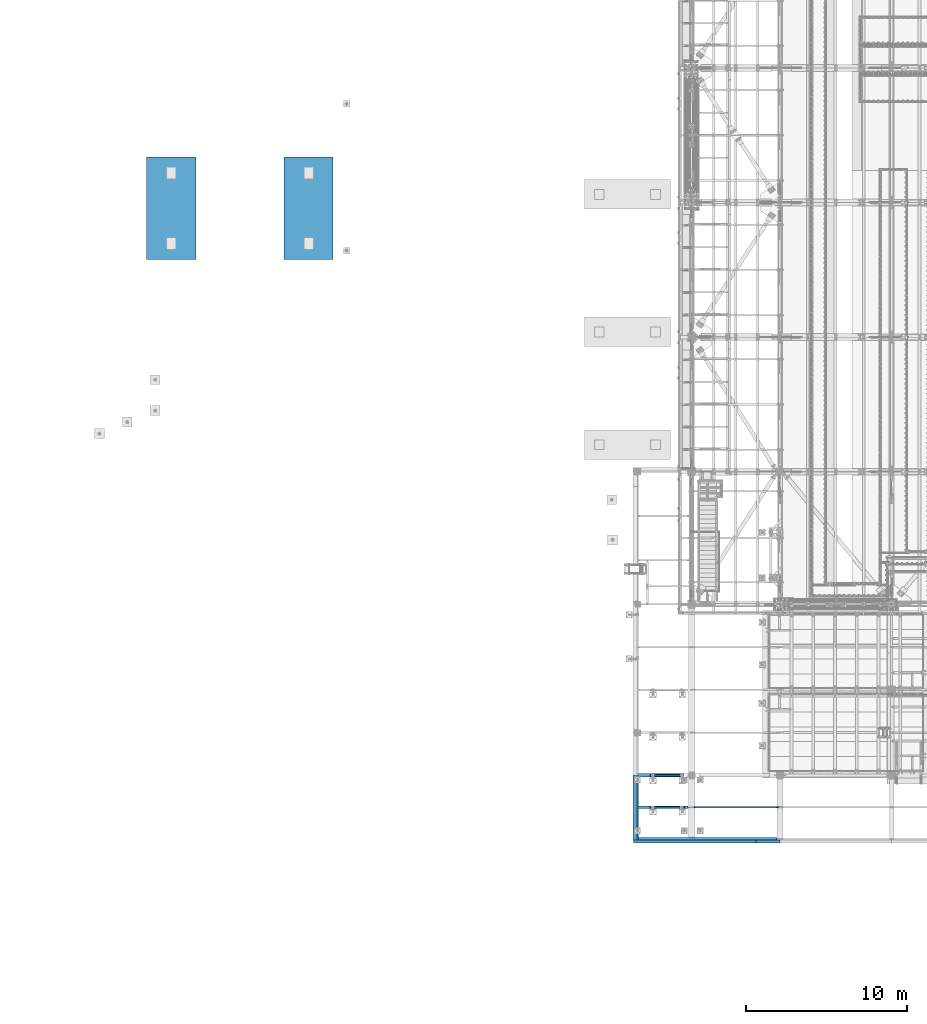
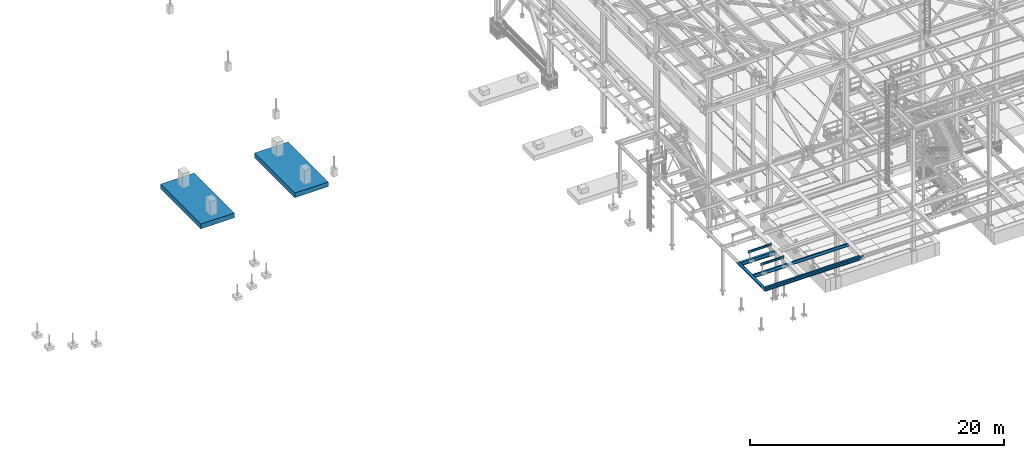
# One storey, part 1737 of 3843: 12 beams, 9 elements without a shape of their own.
"""IFC2X3 building model written with IfcOpenShell, lengths in millimetres."""

from ifc_helpers import new_model, si_unit, frame, origin_with_axes, place, context, subcontext, project, spatial, faceted_brep, material, type_object, element, aggregate, save


model = new_model("IFC2X3")

# Units and contexts
model_context = context("Model", 3, precision=1e-05, world=origin_with_axes())
body_context = subcontext(model_context, "Body", "Model", "MODEL_VIEW")
ifc_project = project(units=[si_unit("LENGTHUNIT", "METRE", prefix="MILLI"), si_unit("AREAUNIT", "SQUARE_METRE"), si_unit("VOLUMEUNIT", "CUBIC_METRE"), si_unit("MASSUNIT", "GRAM", prefix="KILO"), si_unit("TIMEUNIT", "SECOND"), si_unit("PLANEANGLEUNIT", "RADIAN"), si_unit("SOLIDANGLEUNIT", "STERADIAN"), si_unit("THERMODYNAMICTEMPERATUREUNIT", "DEGREE_CELSIUS"), si_unit("LUMINOUSINTENSITYUNIT", "LUMEN")], contexts=[model_context])

# Site, building, storey
site_placement = place(None, origin_with_axes())
site = spatial("IfcSite", under=ifc_project, at=site_placement, CompositionType="ELEMENT")
building_placement = place(site_placement, origin_with_axes())
building = spatial("IfcBuilding", under=site, at=building_placement, Name="Undefined", CompositionType="ELEMENT")
storey_placement = place(building_placement, origin_with_axes())
storey = spatial("IfcBuildingStorey", under=building, at=storey_placement, Name="Undefined", CompositionType="ELEMENT", Elevation=0.0)

# Assembly, beam
assembly_1_placement = place(storey_placement, origin_with_axes())
assembly_1 = element("IfcElementAssembly", 1, at=assembly_1_placement, inside=storey, Name="BEAM", AssemblyPlace="NOTDEFINED", PredefinedType="RIGID_FRAME")
ifc_material_1 = material(Name="STEEL/A992")
beam_type_1 = type_object("IfcBeamType", Name="W12X19", PredefinedType="NOTDEFINED")
beam_1_placement = place(assembly_1_placement, frame((36576.0, 13017.5, 34656.7125), z_axis=(0.0, 0.0, 1.0), x_axis=(1.0, 0.0, 0.0)))
beam_1 = element("IfcBeam", 2, at=beam_1_placement, type_object=beam_type_1, material=ifc_material_1, Name="BEAM", ObjectType="W12X19", context=body_context, shape_type="Brep", body=[
    faceted_brep([(22.2249999999985, -3.47514923012932, -144.462500000001), (22.2249999999985, -3.47492599268662, -153.987500000003), (136.525022932306, -3.4748875878322, -153.987500000003), (136.525022932379, -3.4751108252749, -144.462500000001), (136.525038833555, -50.7999999999993, -144.462500000001), (136.525038833555, -50.7999999999993, -153.987500000003), (5467.35000000001, 50.7999999999993, -144.462500000001), (5467.35000000001, 50.7999999999993, -153.987500000003), (136.52500168042, 50.7999999999993, -153.987500000003), (136.52500168042, 50.7999999999993, -144.462500000001), (136.525017581378, 3.47511084778307, -153.987500000003), (136.525017581444, 3.47488761034037, -144.462500000001), (22.2249999999985, 3.4750724433834, -153.987500000003), (22.2249999999985, 3.4748492059407, -144.462500000001), (22.2249999999985, 3.17499999999927, -144.462500000001), (5467.35000000001, 3.17499999999927, -144.462500000001), (204.88507970878, -3.17499999999927, 110.50422992259), (204.88507970878, 3.17499999999927, 110.50422992259), (200.025000190733, 3.17499999999927, 109.537499999999), (200.025000190733, -3.17499999999927, 109.537499999999), (209.005256176933, -3.17499999999927, 113.257243823064), (209.005256176933, 3.17499999999927, 113.257243823064), (211.758270077407, -3.17499999999927, 117.377420291217), (211.758270077407, 3.17499999999927, 117.377420291217), (212.724999999999, -3.17499999999927, 122.237499809264), (212.724999999999, 3.17499999999927, 122.237499809264), (212.724999999999, -50.7999999999993, 153.987500000003), (212.724999999999, 50.7999999999993, 153.987500000003), (212.724999999999, 50.7999999999993, 144.462500000001), (212.724999999999, 3.17499999999927, 144.462500000001), (212.724999999999, -3.17499999999927, 144.462500000001), (212.724999999999, -50.7999999999993, 144.462500000001), (5283.2, 50.7999999999993, 144.462500000001), (5283.2, 3.17499999999927, 144.462500000001), (5467.35000000001, 3.17499999999927, 103.187500000007), (5467.35000000001, 3.17499999999927, -127.412499999999), (22.2249999999985, 3.17499999999927, -140.112500000003), (22.2249999999985, 3.17499999999927, 90.4875000000029), (22.2249999999985, 3.17499999999927, 109.537499999999), (5283.2, 3.17499999999927, 122.237499809264), (5284.1667299226, 3.17499999999927, 117.377420291217), (5286.91974382307, 3.17499999999927, 113.257243823064), (5291.03992029122, 3.17499999999927, 110.50422992259), (5295.89999980927, 3.17499999999927, 109.537499999999), (5467.35000000001, 3.17499999999927, 109.537499999999), (22.2249999999985, -3.17499999999927, 109.537499999999), (5291.03992029122, -3.17499999999927, 110.50422992259), (5286.91974382307, -3.17499999999927, 113.257243823064), (5284.1667299226, -3.17499999999927, 117.377420291217), (5283.2, -3.17499999999927, 122.237499809264), (5283.2, -3.17499999999927, 144.462500000001), (22.2249999999985, -3.17499999999927, -144.462500000001), (5467.35000000001, -3.17499999999927, -144.462500000001), (5467.35000000001, -3.17499999999927, 109.537499999999), (5295.89999980927, -3.17499999999927, 109.537499999999), (5283.2, -50.7999999999993, 144.462500000001), (5283.2, -50.7999999999993, 153.987500000003), (5283.2, 50.7999999999993, 153.987500000003), (5467.35000000001, -50.7999999999993, -144.462500000001), (5467.35000000001, -50.7999999999993, -153.987500000003)], [[[0, 1, 2, 3]], [[4, 3, 2, 5]], [[6, 7, 8, 9]], [[9, 8, 10, 11]], [[11, 10, 12, 13]], [[14, 15, 6, 9, 11, 13]], [[16, 17, 18, 19]], [[20, 21, 17, 16]], [[22, 23, 21, 20]], [[24, 25, 23, 22]], [[26, 27, 28, 29, 25, 24, 30, 31]], [[29, 28, 32, 33]], [[34, 35, 15, 14, 36, 37, 38, 18, 17, 21, 23, 25, 29, 33, 39, 40, 41, 42, 43, 44]], [[19, 18, 38, 45]], [[46, 47, 48, 49, 50, 30, 24, 22, 20, 16, 19, 45, 51, 52, 53, 54]], [[31, 30, 50, 55]], [[26, 31, 55, 56]], [[27, 26, 56, 57]], [[28, 27, 57, 32]], [[56, 55, 50, 49, 39, 33, 32, 57]], [[48, 40, 39, 49]], [[47, 41, 40, 48]], [[46, 42, 41, 47]], [[54, 43, 42, 46]], [[53, 44, 43, 54]], [[52, 58, 59, 7, 6, 15, 35, 34, 44, 53]], [[59, 58, 4, 5]], [[1, 12, 10, 8, 7, 59, 5, 2]], [[51, 45, 38, 37, 36, 14, 13, 12, 1, 0]], [[58, 52, 51, 0, 3, 4]]]),
])
aggregate(assembly_1, [beam_1])

assembly_2_placement = place(storey_placement, origin_with_axes())
assembly_2 = element("IfcElementAssembly", 3, at=assembly_2_placement, inside=storey, Name="BEAM", AssemblyPlace="NOTDEFINED", PredefinedType="RIGID_FRAME")
beam_2_placement = place(assembly_2_placement, frame((33223.2, 11036.3, 34656.7125), z_axis=(0.0, 0.0, 1.0), x_axis=(0.0, 1.0, 0.0)))
beam_2 = element("IfcBeam", 4, at=beam_2_placement, type_object=beam_type_1, material=ifc_material_1, Name="BEAM", ObjectType="W12X19", context=body_context, shape_type="Brep", body=[
    faceted_brep([(106.362500190742, -3.17500000000291, 122.237500000003), (106.362500190742, 3.17500000000291, 122.237500000003), (17.4624999999942, 3.17500000000291, 122.237500000003), (17.4624999999942, -3.17500000000291, 122.237500000003), (111.222579708789, -3.17500000000291, 123.204229922594), (111.222579708789, 3.17500000000291, 123.204229922594), (115.342756176942, -3.17500000000291, 125.957243823068), (115.342756176942, 3.17500000000291, 125.957243823068), (118.09577007742, -3.17500000000291, 130.077420291222), (118.09577007742, 3.17500000000291, 130.077420291222), (119.062500000007, -3.17500000000291, 134.937499809268), (119.062500000007, 3.17500000000291, 134.937499809268), (119.062500000007, -50.8000000000029, 153.987500000003), (119.062500000007, 50.8000000000029, 153.987500000003), (119.062500000007, 50.8000000000029, 144.462500000001), (119.062500000007, 3.17500000000291, 144.462500000001), (119.062500000007, -3.17500000000291, 144.462500000001), (119.062500000007, -50.8000000000029, 144.462500000001), (17.4624999999942, -3.17500000000291, -144.462500000001), (17.4624999999942, -50.8000000000029, -144.462500000001), (3944.93749999999, -50.8000000000029, -144.462500000001), (3944.93749999999, -3.17500000000291, -144.462500000001), (17.4624999999942, -50.8000000000029, -153.987500000003), (3944.93749999999, -50.8000000000029, -153.987500000003), (17.4624999999942, 50.8000000000029, -153.987500000003), (3944.93749999999, 50.8000000000029, -153.987500000003), (17.4624999999942, 50.8000000000029, -144.462500000001), (3944.93749999999, 50.8000000000029, -144.462500000001), (17.4624999999942, 3.17500000000291, -144.462500000001), (3944.93749999999, 3.17500000000291, -144.462500000001), (3944.93749999999, -3.17500000000291, 115.887499999997), (3944.93749999999, -3.17500000000291, -114.712500000001), (3944.93749999999, 3.17500000000291, 122.237500000003), (3944.93749999999, -3.17500000000291, 122.237500000003), (3856.03749980926, 3.17500000000291, 122.237500000003), (3856.03749980926, -3.17500000000291, 122.237500000003), (3851.17742029121, 3.17500000000291, 123.204229922594), (3851.17742029121, -3.17500000000291, 123.204229922594), (3847.05724382306, 3.17500000000291, 125.957243823068), (3847.05724382306, -3.17500000000291, 125.957243823068), (3844.30422992258, 3.17500000000291, 130.077420291222), (3844.30422992258, -3.17500000000291, 130.077420291222), (3843.33749999999, 3.17500000000291, 134.937499809268), (3843.33749999999, -3.17500000000291, 134.937499809268), (3843.33749999999, -50.8000000000029, 153.987500000003), (3843.33749999999, -50.8000000000029, 144.462500000001), (3843.33749999999, -3.17500000000291, 144.462500000001), (3843.33749999999, 3.17500000000291, 144.462500000001), (3843.33749999999, 50.8000000000029, 144.462500000001), (3843.33749999999, 50.8000000000029, 153.987500000003), (17.4625000000015, -3.17500000000291, 115.887499999997), (17.4625000000015, -3.17500000000291, -114.712500000001)], [[[0, 1, 2, 3]], [[4, 5, 1, 0]], [[6, 7, 5, 4]], [[8, 9, 7, 6]], [[10, 11, 9, 8]], [[12, 13, 14, 15, 11, 10, 16, 17]], [[18, 19, 20, 21]], [[19, 22, 23, 20]], [[22, 24, 25, 23]], [[24, 26, 27, 25]], [[26, 28, 29, 27]], [[30, 31, 21, 20, 23, 25, 27, 29, 32, 33]], [[33, 32, 34, 35]], [[35, 34, 36, 37]], [[37, 36, 38, 39]], [[39, 38, 40, 41]], [[41, 40, 42, 43]], [[44, 45, 46, 43, 42, 47, 48, 49]], [[45, 44, 12, 17]], [[46, 45, 17, 16]], [[8, 6, 4, 0, 3, 50, 51, 18, 21, 31, 30, 33, 35, 37, 39, 41, 43, 46, 16, 10]], [[28, 26, 24, 22, 19, 18, 51, 50, 3, 2]], [[47, 42, 40, 38, 36, 34, 32, 29, 28, 2, 1, 5, 7, 9, 11, 15]], [[48, 47, 15, 14]], [[49, 48, 14, 13]], [[44, 49, 13, 12]]]),
])

assembly_3_placement = place(storey_placement, origin_with_axes())
assembly_3 = element("IfcElementAssembly", 5, at=assembly_3_placement, inside=storey, Name="BEAM", AssemblyPlace="NOTDEFINED", PredefinedType="RIGID_FRAME")
beam_type_2 = type_object("IfcBeamType", Name="W8X13", PredefinedType="NOTDEFINED")
beam_3_placement = place(assembly_3_placement, frame((36118.8, 13017.5, 35521.8999969482), z_axis=(0.0, 0.0, 1.0), x_axis=(-1.0, 0.0, 0.0)))
beam_3 = element("IfcBeam", 6, at=beam_3_placement, type_object=beam_type_2, material=ifc_material_1, Name="BEAM", ObjectType="W8X13", context=body_context, shape_type="Brep", body=[
    faceted_brep([(0.0, 50.7999999999993, -101.599999999999), (0.0, 50.7999999999993, -95.25), (2133.6, 50.7999999999993, -95.25), (2133.6, 50.7999999999993, -101.599999999999), (0.0, 3.17499999999927, -95.25), (2133.6, 3.17499999999927, -95.25), (-2.44140610448085e-05, 3.17500000000291, 95.2499999999927), (2133.6, 3.17499999999927, 95.25), (0.0, 50.7999999999993, 95.25), (2133.6, 50.7999999999993, 95.25), (0.0, 50.7999999999993, 101.599999999999), (2133.6, 50.7999999999993, 101.599999999999), (0.0, -50.7999999999993, 101.599999999999), (2133.6, -50.7999999999993, 101.599999999999), (0.0, -50.7999999999993, 95.25), (2133.6, -50.7999999999993, 95.25), (0.0, -3.17499999999927, 95.25), (2133.6, -3.17499999999927, 95.25), (0.0, -3.17499999999927, -95.25), (2133.6, -3.17499999999927, -95.25), (0.0, -50.7999999999993, -95.25), (2133.6, -50.7999999999993, -95.25), (0.0, -50.7999999999993, -101.599999999999), (2133.6, -50.7999999999993, -101.599999999999)], [[[0, 1, 2, 3]], [[1, 4, 5, 2]], [[4, 6, 7, 5]], [[6, 8, 9, 7]], [[8, 10, 11, 9]], [[10, 12, 13, 11]], [[12, 14, 15, 13]], [[14, 16, 17, 15]], [[16, 18, 19, 17]], [[18, 20, 21, 19]], [[20, 22, 23, 21]], [[22, 0, 3, 23]], [[5, 7, 9, 11, 13, 15, 17, 19, 21, 23, 3, 2]], [[22, 20, 18, 16, 14, 12, 10, 8, 6, 4, 1, 0]]]),
])
aggregate(assembly_3, [beam_3])

assembly_4_placement = place(storey_placement, origin_with_axes())
assembly_4 = element("IfcElementAssembly", 7, at=assembly_4_placement, inside=storey, Name="BEAM", AssemblyPlace="NOTDEFINED", PredefinedType="RIGID_FRAME")
beam_4_placement = place(assembly_4_placement, frame((36118.8, 14998.7, 35521.8999969482), z_axis=(0.0, 0.0, 1.0), x_axis=(-1.0, 0.0, 0.0)))
beam_4 = element("IfcBeam", 8, at=beam_4_placement, type_object=beam_type_2, material=ifc_material_1, Name="BEAM", ObjectType="W8X13", context=body_context, shape_type="Brep", body=[
    faceted_brep([(0.0, 50.7999999999993, -101.599999999999), (0.0, 50.7999999999993, -95.25), (2133.6, 50.7999999999993, -95.25), (2133.6, 50.7999999999993, -101.599999999999), (0.0, 3.17499999999927, -95.25), (2133.6, 3.17499999999927, -95.25), (-2.44140610448085e-05, 3.17500000000291, 95.2499999999927), (2133.6, 3.17499999999927, 95.25), (0.0, 50.7999999999993, 95.25), (2133.6, 50.7999999999993, 95.25), (0.0, 50.7999999999993, 101.599999999999), (2133.6, 50.7999999999993, 101.599999999999), (0.0, -50.7999999999993, 101.599999999999), (2133.6, -50.7999999999993, 101.599999999999), (0.0, -50.7999999999993, 95.25), (2133.6, -50.7999999999993, 95.25), (0.0, -3.17499999999927, 95.25), (2133.6, -3.17499999999927, 95.25), (0.0, -3.17499999999927, -95.25), (2133.6, -3.17499999999927, -95.25), (0.0, -50.7999999999993, -95.25), (2133.6, -50.7999999999993, -95.25), (0.0, -50.7999999999993, -101.599999999999), (2133.6, -50.7999999999993, -101.599999999999)], [[[0, 1, 2, 3]], [[1, 4, 5, 2]], [[4, 6, 7, 5]], [[6, 8, 9, 7]], [[8, 10, 11, 9]], [[10, 12, 13, 11]], [[12, 14, 15, 13]], [[14, 16, 17, 15]], [[16, 18, 19, 17]], [[18, 20, 21, 19]], [[20, 22, 23, 21]], [[22, 0, 3, 23]], [[5, 7, 9, 11, 13, 15, 17, 19, 21, 23, 3, 2]], [[22, 20, 18, 16, 14, 12, 10, 8, 6, 4, 1, 0]]]),
])
aggregate(assembly_4, [beam_4])

# Beam
ifc_material_2 = material(Name="STEEL/A36")
beam_type_3 = type_object("IfcBeamType", PredefinedType="NOTDEFINED")
beam_5_placement = place(assembly_2_placement, frame((33223.2, 12993.8855, 34813.875), z_axis=(0.0, -1.0, 0.0), x_axis=(-1.0, 0.0, 0.0)))
beam_5 = element("IfcBeam", 9, at=beam_5_placement, type_object=beam_type_3, material=ifc_material_2, Name="BENT_PLATE", context=body_context, shape_type="Brep", body=[
    faceted_brep([(0.0, -3.17500000000291, -2002.036), (0.0, -3.17500000000291, 2002.036), (0.0, 3.17500000000291, 2002.036), (0.0, 3.17500000000291, -2002.036), (279.399993896484, 3.17500000000291, 2002.036), (279.399993896484, 3.17500000000291, -2002.036), (273.049993896479, -3.17500000000291, -2002.036), (273.049993896479, -3.17500000000291, 2002.036), (279.399993896484, -136.524996948239, 2002.036), (279.399993896484, -136.524996948239, -2002.036), (273.049993896479, -136.524996948239, 2002.036), (273.049993896479, -136.524996948239, -2002.036)], [[[0, 1, 2, 3]], [[3, 2, 4, 5]], [[1, 0, 6, 7]], [[5, 4, 8, 9]], [[4, 2, 1, 7, 10, 8]], [[7, 6, 11, 10]], [[6, 0, 3, 5, 9, 11]], [[10, 11, 9, 8]]]),
])

aggregate(assembly_2, [beam_5, beam_2])

# Assembly, beams
assembly_5_placement = place(storey_placement, origin_with_axes())
assembly_5 = element("IfcElementAssembly", 10, at=assembly_5_placement, inside=storey, Name="BEAM", AssemblyPlace="NOTDEFINED", PredefinedType="RIGID_FRAME")
beam_type_4 = type_object("IfcBeamType", PredefinedType="NOTDEFINED")
beam_6_placement = place(assembly_5_placement, frame((36753.8, 10985.5, 34813.875), z_axis=(-1.0, 0.0, 0.0), x_axis=(0.0, -1.0, 0.0)))
beam_6 = element("IfcBeam", 11, at=beam_6_placement, type_object=beam_type_4, material=ifc_material_2, Name="BENT_PLATE", context=body_context, shape_type="Brep", body=[
    faceted_brep([(0.0, -3.17500000000291, -3810.0), (0.0, -3.17500000000291, 3810.0), (0.0, 3.17500000000291, 3810.0), (0.0, 3.17500000000291, -3810.0), (171.450003051756, 3.17500000000291, 3810.0), (171.450003051756, 3.17500000000291, -3810.0), (177.800003051754, -3.17500000000291, -3810.0), (177.800003051754, -3.17500000000291, 3810.0), (171.450003051756, 136.524996948239, 3810.0), (171.450003051756, 136.524996948239, -3810.0), (177.800003051754, 136.524996948239, 3810.0), (177.800003051754, 136.524996948239, -3810.0)], [[[0, 1, 2, 3]], [[3, 2, 4, 5]], [[1, 0, 6, 7]], [[5, 4, 8, 9]], [[4, 2, 1, 7, 10, 8]], [[7, 6, 11, 10]], [[6, 0, 3, 5, 9, 11]], [[10, 11, 9, 8]]]),
])
beam_7_placement = place(assembly_5_placement, frame((41311.5125, 10985.5, 34813.875), z_axis=(-1.0, 0.0, 0.0), x_axis=(0.0, -1.0, 0.0)))
beam_7 = element("IfcBeam", 12, at=beam_7_placement, type_object=beam_type_4, material=ifc_material_2, Name="BENT_PLATE", context=body_context, shape_type="Brep", body=[
    faceted_brep([(174.625003051762, 7.27595761418343e-12, 747.712500000009), (171.450003051756, 3.17500000000291, 744.537500000006), (0.0, 3.17500000000291, 744.537500000006), (0.0, 7.27595761418343e-12, 747.712500000001), (174.625003051762, 136.524996948239, 747.712500000001), (171.450003051756, 136.524996948239, 744.537500000006), (177.800003051754, -3.17500000000291, -747.712500000001), (0.0, -3.17500000000291, -747.712500000001), (0.0, 3.17500000000291, -747.712500000001), (171.450003051756, 3.17500000000291, -747.712500000001), (171.450003051756, 136.524996948239, -747.712500000001), (177.800003051754, 136.524996948239, -747.712500000001), (177.800003051754, -3.17500000000291, 747.712500000001), (177.800003051754, 136.524996948239, 747.712500000001), (0.0, -3.17500000000291, 747.712500000001)], [[[0, 1, 2, 3]], [[4, 5, 1, 0]], [[6, 7, 8, 9, 10, 11]], [[12, 6, 11, 13]], [[14, 7, 6, 12]], [[8, 7, 14, 3, 2]], [[9, 8, 2, 1]], [[10, 9, 1, 5]], [[13, 11, 10, 5, 4]], [[14, 12, 13, 4, 0, 3]]]),
])

# Assembly, beam
assembly_6_placement = place(storey_placement, origin_with_axes())
assembly_6 = element("IfcElementAssembly", 13, at=assembly_6_placement, inside=storey, Name="BEAM", AssemblyPlace="NOTDEFINED", PredefinedType="RIGID_FRAME")
beam_type_5 = type_object("IfcBeamType", Name="W14X22", PredefinedType="NOTDEFINED")
beam_8_placement = place(assembly_6_placement, frame((33223.2, 13017.5, 34636.075), z_axis=(0.0, 0.0, 1.0), x_axis=(1.0, 0.0, 0.0)))
beam_8 = element("IfcBeam", 14, at=beam_8_placement, type_object=beam_type_5, material=ifc_material_1, Name="BEAM", ObjectType="W14X22", context=body_context, shape_type="Brep", body=[
    faceted_brep([(15.875, -3.17499999999927, -111.124999999985), (15.875, 3.17499999999927, -111.124999999985), (50.8000001907494, 3.17499999999927, -111.124999999985), (50.8000001907494, -3.17499999999927, -111.124999999985), (55.6600797087958, 3.17499999999927, -112.091729922577), (55.6600797087958, -3.17499999999927, -112.091729922577), (59.7802561769495, 3.17499999999927, -114.844743823051), (59.7802561769495, -3.17499999999927, -114.844743823051), (62.5332700774234, 3.17499999999927, -118.964920291204), (62.5332700774234, -3.17499999999927, -118.964920291204), (63.5000000000146, -3.17499999999927, -123.824999809251), (63.5000000000146, 3.17499999999927, -123.824999809251), (63.5000000000146, 3.17499999999927, -166.6875), (63.5000000000146, 63.5, -166.6875), (63.5000000000146, 63.5, -174.625), (63.5000000000146, -63.5, -174.625), (63.5000000000146, -63.5, -166.6875), (63.5000000000146, -3.17499999999927, -166.6875), (63.5000000000146, 3.17499999999927, 166.6875), (63.5000000000146, 63.5, 166.6875), (3141.66250000001, 63.5, 166.6875), (3141.66250000001, 3.17499999999927, 166.6875), (50.8000001907494, -3.17499999999927, 149.225000000013), (50.8000001907494, 3.17499999999927, 149.225000000013), (15.875, 3.17499999999927, 149.225000000013), (15.875, -3.17499999999927, 149.225000000013), (55.6600797087958, -3.17499999999927, 150.191729922604), (55.6600797087958, 3.17499999999927, 150.191729922604), (59.7802561769495, -3.17499999999927, 152.944743823078), (59.7802561769495, 3.17499999999927, 152.944743823078), (62.5332700774234, -3.17499999999927, 157.064920291232), (62.5332700774234, 3.17499999999927, 157.064920291232), (63.5000000000146, -3.17499999999927, 161.924999809278), (63.5000000000146, 3.17499999999927, 161.924999809278), (63.5000000000146, -63.5, 174.625), (63.5000000000146, 63.5, 174.625), (63.5000000000146, -3.17499999999927, 166.6875), (63.5000000000146, -63.5, 166.6875), (3141.66250000001, -3.17499999999927, 166.6875), (3141.66250000001, -63.5, 166.6875), (3141.66250000001, -63.5, 174.625), (3141.66250000001, 63.5, 174.625), (3141.66250000001, -3.17499999999927, 142.874999809268), (3141.66250000001, 3.17499999999927, 142.874999809268), (3142.6292299226, -3.17499999999927, 138.014920291222), (3142.6292299226, 3.17499999999927, 138.014920291222), (3145.38224382308, -3.17499999999927, 133.894743823068), (3145.38224382308, 3.17499999999927, 133.894743823068), (3149.50242029123, -3.17499999999927, 131.141729922594), (3149.50242029123, 3.17499999999927, 131.141729922594), (3154.36249980928, -3.17499999999927, 130.175000000003), (3154.36249980928, 3.17499999999927, 130.175000000003), (3330.575, -3.17499999999927, 130.175000000003), (3330.575, 3.17499999999927, 130.175000000003), (3330.575, 3.17499999999927, -119.475000000006), (3330.575, 3.17499999999927, 111.125), (3330.575, -3.17499999999927, -130.174999999996), (3330.575, 3.17499999999927, -130.174999999996), (3154.36249980928, -3.17499999999927, -130.174999999996), (3154.36249980928, 3.17499999999927, -130.174999999996), (3149.50242029123, -3.17499999999927, -131.141729922587), (3149.50242029123, 3.17499999999927, -131.141729922587), (3145.38224382308, -3.17499999999927, -133.894743823061), (3145.38224382308, 3.17499999999927, -133.894743823061), (3142.6292299226, -3.17499999999927, -138.014920291214), (3142.6292299226, 3.17499999999927, -138.014920291214), (3141.66250000001, -3.17499999999927, -142.874999809261), (3141.66250000001, 3.17499999999927, -142.874999809261), (3141.66250000001, -3.17499999999927, -166.6875), (3141.66250000001, -63.5, -166.6875), (3141.66250000001, -63.5, -174.625), (3141.66250000001, 63.5, -174.625), (3141.66250000001, 63.5, -166.6875), (3141.66250000001, 3.17499999999927, -166.6875), (15.875, 3.17499999999927, -94.0750000000044), (15.875, 3.17499999999927, 136.524999999994)], [[[0, 1, 2, 3]], [[3, 2, 4, 5]], [[5, 4, 6, 7]], [[7, 6, 8, 9]], [[10, 11, 12, 13, 14, 15, 16, 17]], [[9, 8, 11, 10]], [[18, 19, 20, 21]], [[22, 23, 24, 25]], [[26, 27, 23, 22]], [[28, 29, 27, 26]], [[30, 31, 29, 28]], [[32, 33, 31, 30]], [[34, 35, 19, 18, 33, 32, 36, 37]], [[37, 36, 38, 39]], [[34, 37, 39, 40]], [[35, 34, 40, 41]], [[19, 35, 41, 20]], [[40, 39, 38, 42, 43, 21, 20, 41]], [[44, 45, 43, 42]], [[46, 47, 45, 44]], [[48, 49, 47, 46]], [[50, 51, 49, 48]], [[52, 53, 51, 50]], [[54, 55, 53, 52, 56, 57]], [[56, 58, 59, 57]], [[60, 61, 59, 58]], [[62, 63, 61, 60]], [[64, 65, 63, 62]], [[66, 67, 65, 64]], [[68, 69, 70, 71, 72, 73, 67, 66]], [[69, 68, 17, 16]], [[70, 69, 16, 15]], [[71, 70, 15, 14]], [[72, 71, 14, 13]], [[73, 72, 13, 12]], [[6, 4, 2, 1, 74, 75, 24, 23, 27, 29, 31, 33, 18, 21, 43, 45, 47, 49, 51, 53, 55, 54, 57, 59, 61, 63, 65, 67, 73, 12, 11, 8]], [[25, 24, 75, 74, 1, 0]], [[68, 66, 64, 62, 60, 58, 56, 52, 50, 48, 46, 44, 42, 38, 36, 32, 30, 28, 26, 22, 25, 0, 3, 5, 7, 9, 10, 17]]]),
])
aggregate(assembly_6, [beam_8])

# Beam
beam_type_6 = type_object("IfcBeamType", Name="W14X53", PredefinedType="NOTDEFINED")
beam_9_placement = place(assembly_5_placement, frame((33172.4, 11036.3, 34634.4875), z_axis=(0.0, 0.0, 1.0), x_axis=(1.0, 0.0, 0.0)))
beam_9 = element("IfcBeam", 15, at=beam_9_placement, type_object=beam_type_6, material=ifc_material_1, Name="BEAM", ObjectType="W14X53", context=body_context, shape_type="Brep", body=[
    faceted_brep([(8693.15000000001, -4.76250000000073, -158.75), (8693.15000000001, -101.6, -158.75), (8693.15000000001, -101.6, -176.212500000001), (8693.15000000001, 101.6, -176.212500000001), (8693.15000000001, 101.6, -158.75), (8693.15000000001, 4.76250000000073, -158.75), (8693.15000000001, 4.76250000000073, -157.162499809267), (8693.15000000001, -4.76250000000073, -157.162499809267), (8694.11672992259, 4.76250000000073, -152.30242029122), (8694.11672992259, -4.76250000000073, -152.30242029122), (8696.86974382307, 4.76250000000073, -148.182243823067), (8696.86974382307, -4.76250000000073, -148.182243823067), (8700.98992029123, 4.76250000000073, -145.429229922593), (8700.98992029123, -4.76250000000073, -145.429229922593), (8705.84999980927, 4.76250000000073, -144.462500000001), (8705.84999980927, -4.76250000000073, -144.462500000001), (8870.95000000001, -4.76250000000073, -144.462500000001), (8870.95000000001, 4.76250000000073, -144.462500000001), (0.0, 4.76249999999709, 158.749999526888), (0.0, 101.6, 158.75), (8693.15000000001, 101.6, 158.75), (8693.15000000001, 4.76250000000073, 158.75), (0.0, -101.6, -176.212500000001), (0.0, -101.6, -158.75), (0.0, -4.76250000000073, -158.75), (0.0, -4.76249999999709, 158.749999526888), (0.0, -101.6, 158.75), (0.0, -101.6, 176.212500000001), (0.0, 101.6, 176.212500000001), (0.0, 4.76250000000073, -158.75), (0.0, 101.6, -158.75), (0.0, 101.6, -176.212500000001), (8693.15000000001, -4.76250000000073, 158.75), (8693.15000000001, -101.6, 158.75), (8693.15000000001, -101.6, 176.212500000001), (8693.15000000001, 101.6, 176.212500000001), (8693.15000000001, -4.76250000000073, 157.162499809267), (8693.15000000001, 4.76250000000073, 157.162499809267), (8694.11672992259, -4.76250000000073, 152.30242029122), (8694.11672992259, 4.76250000000073, 152.30242029122), (8696.86974382307, -4.76250000000073, 148.182243823067), (8696.86974382307, 4.76250000000073, 148.182243823067), (8700.98992029123, -4.76250000000073, 145.429229922593), (8700.98992029123, 4.76250000000073, 145.429229922593), (8705.84999980927, -4.76250000000073, 144.462500000001), (8705.84999980927, 4.76250000000073, 144.462500000001), (8870.95000000001, -4.76250000000073, 144.462500000001), (8870.95000000001, 4.76250000000073, 144.462500000001), (8870.95000000001, 4.76250000000073, -92.4875000000029), (8870.95000000001, 4.76250000000073, 138.112500000003)], [[[0, 1, 2, 3, 4, 5, 6, 7]], [[7, 6, 8, 9]], [[9, 8, 10, 11]], [[11, 10, 12, 13]], [[13, 12, 14, 15]], [[16, 15, 14, 17]], [[18, 19, 20, 21]], [[22, 23, 24, 25, 26, 27, 28, 19, 18, 29, 30, 31]], [[26, 25, 32, 33]], [[27, 26, 33, 34]], [[28, 27, 34, 35]], [[19, 28, 35, 20]], [[34, 33, 32, 36, 37, 21, 20, 35]], [[38, 39, 37, 36]], [[40, 41, 39, 38]], [[42, 43, 41, 40]], [[44, 45, 43, 42]], [[46, 47, 45, 44]], [[48, 49, 47, 46, 16, 17]], [[12, 10, 8, 6, 5, 29, 18, 21, 37, 39, 41, 43, 45, 47, 49, 48, 17, 14]], [[30, 29, 5, 4]], [[31, 30, 4, 3]], [[22, 31, 3, 2]], [[23, 22, 2, 1]], [[24, 23, 1, 0]], [[46, 44, 42, 40, 38, 36, 32, 25, 24, 0, 7, 9, 11, 13, 15, 16]]]),
])

aggregate(assembly_5, [beam_6, beam_7, beam_9])

# Assembly, beam
assembly_7_placement = place(storey_placement, origin_with_axes())
assembly_7 = element("IfcElementAssembly", 16, at=assembly_7_placement, inside=storey, Name="BEAM", AssemblyPlace="NOTDEFINED", PredefinedType="RIGID_FRAME")
beam_10_placement = place(assembly_7_placement, frame((33172.4, 14998.7, 34634.4875), z_axis=(0.0, 0.0, 1.0), x_axis=(1.0, 0.0, 0.0)))
beam_10 = element("IfcBeam", 17, at=beam_10_placement, type_object=beam_type_6, material=ifc_material_1, Name="BEAM", ObjectType="W14X53", context=body_context, shape_type="Brep", body=[
    faceted_brep([(3184.63795585983, -4.76250000000073, -158.352999496463), (3184.63795585983, -4.76250000000073, -158.75), (3184.63795585983, -101.6, -158.75), (3184.63795585983, -101.6, -176.212500000001), (3184.63795585983, 101.6, -176.212500000001), (3184.63795585983, 101.6, -158.75), (3184.63795585983, 4.76250000000073, -158.75), (3184.63795585983, 4.76250000000073, -158.352999496463), (0.0, 101.6, 158.75), (0.0, 101.6, 176.212500000001), (3185.55539706808, 101.6, 176.212500000001), (3195.63701066062, 101.6, 158.75), (0.0, 4.76249999999709, 158.749999526888), (3195.63701066062, 4.76250000000073, 158.75), (0.0, -101.6, -176.212500000001), (0.0, -101.6, -158.75), (0.0, -4.76250000000073, -158.75), (0.0, -4.76249999999709, 158.749999526888), (0.0, -101.6, 158.75), (0.0, -101.6, 176.212500000001), (0.0, 4.76250000000073, -158.75), (0.0, 101.6, -158.75), (0.0, 101.6, -176.212500000001), (3195.63701066062, -4.76250000000073, 158.75), (3195.63701066062, -101.6, 158.75), (3185.55539706808, -101.6, 176.212500000001), (3195.86621069914, -4.76250000000073, 158.352999496463), (3195.86621069914, 4.76250000000073, 158.352999496463), (3170.23699645996, -4.76250000000073, 158.352999496463), (3170.23699645996, 4.76250000000073, 158.352999496463), (3123.64355204476, -4.76250000000073, 149.040259440721), (3123.64355204476, 4.76250000000073, 149.040259440721), (3118.7702468861, -4.76250000000073, 146.430214982844), (3118.7702468861, 4.76250000000073, 146.430214982844), (3116.16740413041, -4.76250000000073, 141.553059579281), (3116.16740413041, 4.76250000000073, 141.553059579281), (3116.71180601745, -4.76250000000073, 136.051690492699), (3116.71180601745, 4.76250000000073, 136.051690492699), (3120.22006770587, -4.76250000000073, 131.779274880071), (3120.22006770587, 4.76250000000073, 131.779274880071), (3125.51041148965, -4.76250000000073, 130.175000000003), (3125.51041148965, 4.76250000000073, 130.175000000003), (3381.37500000001, -4.76250000000073, 130.175000000003), (3381.37500000001, 4.76250000000073, 130.175000000003), (3381.37500000001, -4.76250000000073, -130.175000000003), (3381.37500000001, 4.76250000000073, -130.175000000003), (3127.67041075723, -4.76250000000073, -130.175000000003), (3127.67041075723, 4.76250000000073, -130.175000000003), (3122.38006697346, -4.76250000000073, -131.779274880071), (3122.38006697346, 4.76250000000073, -131.779274880071), (3118.87180528504, -4.76250000000073, -136.051690492699), (3118.87180528504, 4.76250000000073, -136.051690492699), (3118.32740339799, -4.76250000000073, -141.553059579281), (3118.32740339799, 4.76250000000073, -141.553059579281), (3120.93024615368, -4.76250000000073, -146.430214982844), (3120.93024615368, 4.76250000000073, -146.430214982844), (3125.80355131233, -4.76250000000073, -149.040259440721), (3125.80355131233, 4.76250000000073, -149.040259440721), (3172.39699572754, -4.76250000000073, -158.352999496463), (3172.39699572754, 4.76250000000073, -158.352999496463)], [[[0, 1, 2, 3, 4, 5, 6, 7]], [[8, 9, 10, 11]], [[12, 8, 11, 13]], [[14, 15, 16, 17, 18, 19, 9, 8, 12, 20, 21, 22]], [[18, 17, 23, 24]], [[19, 18, 24, 25]], [[9, 19, 25, 10]], [[24, 23, 26, 27, 13, 11, 10, 25]], [[28, 29, 27, 26]], [[30, 31, 29, 28]], [[32, 33, 31, 30]], [[34, 35, 33, 32]], [[36, 37, 35, 34]], [[38, 39, 37, 36]], [[40, 41, 39, 38]], [[41, 40, 42, 43]], [[42, 44, 45, 43]], [[46, 47, 45, 44]], [[48, 49, 47, 46]], [[50, 51, 49, 48]], [[52, 53, 51, 50]], [[54, 55, 53, 52]], [[56, 57, 55, 54]], [[58, 59, 57, 56]], [[59, 58, 0, 7]], [[20, 12, 13, 27, 29, 31, 33, 35, 37, 39, 41, 43, 45, 47, 49, 51, 53, 55, 57, 59, 7, 6]], [[21, 20, 6, 5]], [[22, 21, 5, 4]], [[14, 22, 4, 3]], [[15, 14, 3, 2]], [[16, 15, 2, 1]], [[58, 56, 54, 52, 50, 48, 46, 44, 42, 40, 38, 36, 34, 32, 30, 28, 26, 23, 17, 16, 1, 0]]]),
])
aggregate(assembly_7, [beam_10])

assembly_8_placement = place(storey_placement, origin_with_axes())
assembly_8 = element("IfcElementAssembly", 18, at=assembly_8_placement, inside=storey, Name="BEAM", AssemblyPlace="NOTDEFINED", PredefinedType="REINFORCEMENT_UNIT")
ifc_material_3 = material(Name="CONCRETE/5000")
beam_type_7 = type_object("IfcBeamType", PredefinedType="NOTDEFINED")
beam_11_placement = place(assembly_8_placement, frame((12801.6, 47028.1, 29489.4), z_axis=(0.0, 0.0, 1.0), x_axis=(0.0, 1.0, 0.0)))
beam_11 = element("IfcBeam", 19, at=beam_11_placement, type_object=beam_type_7, material=ifc_material_3, Name="BEAM", context=body_context, shape_type="Brep", body=[
    faceted_brep([(0.0, 1524.0, -228.599999999999), (0.0, 1524.0, 228.599999999999), (6350.0, 1524.0, 228.599999999999), (6350.0, 1524.0, -228.599999999999), (0.0, -1524.0, 228.599999999999), (6350.0, -1524.0, 228.599999999999), (0.0, -1524.0, -228.599999999999), (6350.0, -1524.0, -228.599999999999)], [[[0, 1, 2, 3]], [[1, 4, 5, 2]], [[4, 6, 7, 5]], [[6, 0, 3, 7]], [[5, 7, 3, 2]], [[6, 4, 1, 0]]]),
])
aggregate(assembly_8, [beam_11])

assembly_9_placement = place(storey_placement, origin_with_axes())
assembly_9 = element("IfcElementAssembly", 20, at=assembly_9_placement, inside=storey, Name="BEAM", AssemblyPlace="NOTDEFINED", PredefinedType="REINFORCEMENT_UNIT")
beam_12_placement = place(assembly_9_placement, frame((4267.20000000001, 47028.1, 29489.4), z_axis=(0.0, 0.0, 1.0), x_axis=(0.0, 1.0, 0.0)))
beam_12 = element("IfcBeam", 21, at=beam_12_placement, type_object=beam_type_7, material=ifc_material_3, Name="BEAM", context=body_context, shape_type="Brep", body=[
    faceted_brep([(0.0, 1524.0, -228.599999999999), (0.0, 1524.0, 228.599999999999), (6350.0, 1524.0, 228.599999999999), (6350.0, 1524.0, -228.599999999999), (0.0, -1524.0, 228.599999999999), (6350.0, -1524.0, 228.599999999999), (0.0, -1524.0, -228.599999999999), (6350.0, -1524.0, -228.599999999999)], [[[0, 1, 2, 3]], [[1, 4, 5, 2]], [[4, 6, 7, 5]], [[6, 0, 3, 7]], [[5, 7, 3, 2]], [[6, 4, 1, 0]]]),
])
aggregate(assembly_9, [beam_12])

save(model, "model.ifc")
